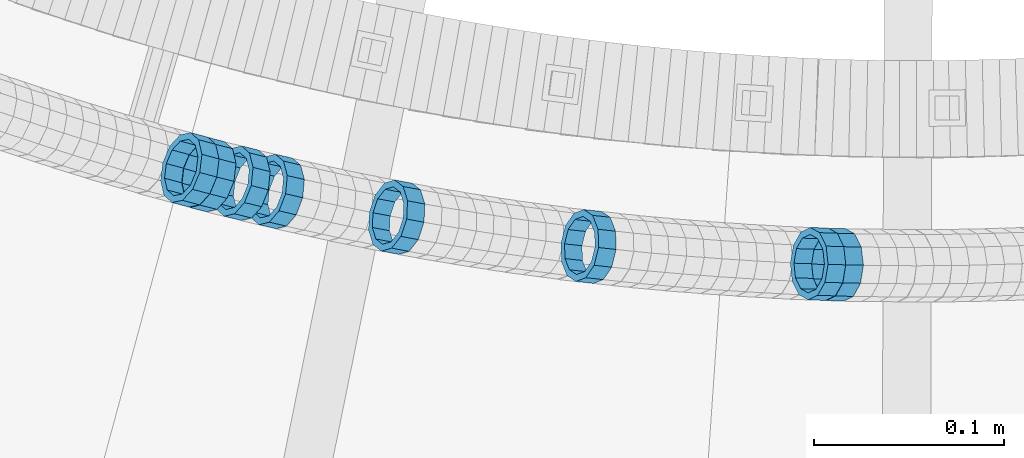
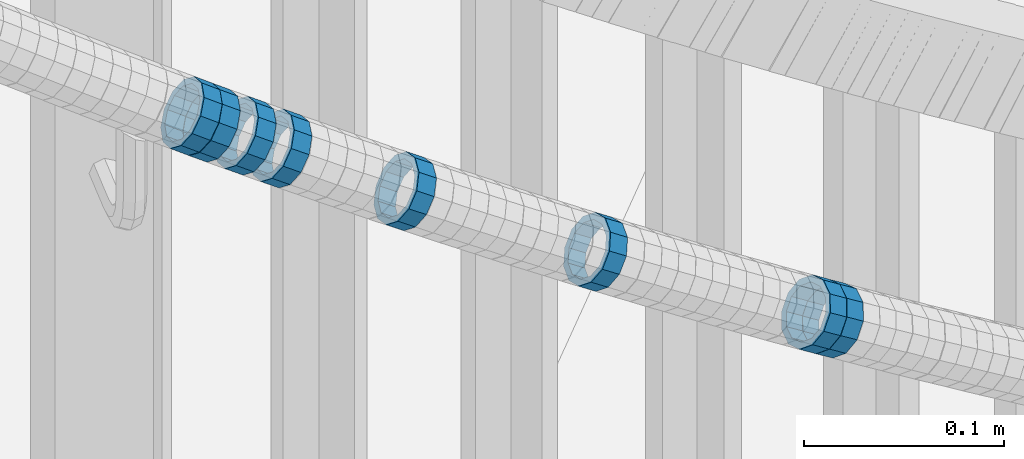
# One storey, part 686 of 975: 8 members.
"""IFC2X3 building model written with IfcOpenShell, lengths in millimetres."""

from ifc_helpers import new_model, si_unit, frame, origin_with_axes, place, context, subcontext, project, spatial, faceted_brep, material, type_object, element, save


model = new_model("IFC2X3")

# Units and contexts
model_context = context("Model", 3, precision=1e-05, world=origin_with_axes())
body_context = subcontext(model_context, "Body", "Model", "MODEL_VIEW")
ifc_project = project(units=[si_unit("LENGTHUNIT", "METRE", prefix="MILLI"), si_unit("AREAUNIT", "SQUARE_METRE"), si_unit("VOLUMEUNIT", "CUBIC_METRE"), si_unit("MASSUNIT", "GRAM", prefix="KILO"), si_unit("TIMEUNIT", "SECOND"), si_unit("PLANEANGLEUNIT", "RADIAN"), si_unit("SOLIDANGLEUNIT", "STERADIAN"), si_unit("THERMODYNAMICTEMPERATUREUNIT", "DEGREE_CELSIUS"), si_unit("LUMINOUSINTENSITYUNIT", "LUMEN")], contexts=[model_context])

# Site, building, storey
site_placement = place(None, origin_with_axes())
site = spatial("IfcSite", under=ifc_project, at=site_placement, CompositionType="ELEMENT")
building_placement = place(site_placement, origin_with_axes())
building = spatial("IfcBuilding", under=site, at=building_placement, Name="Undefined", CompositionType="ELEMENT")
storey_placement = place(building_placement, origin_with_axes())
storey = spatial("IfcBuildingStorey", under=building, at=storey_placement, Name="Undefined", CompositionType="ELEMENT", Elevation=0.0)

# Members
ifc_material = material()
member_type = type_object("IfcMemberType", PredefinedType="NOTDEFINED")
member_1_placement = place(storey_placement, frame((34566.3645562192, 1933.58696290878, 4310.87991200936), z_axis=(-0.108059180815137, -0.994144463064379, -1.17480340122711e-10), x_axis=(-0.846462505067043, 0.0920067940072997, 0.524438726041588)))
element("IfcMember", 1, at=member_1_placement, inside=storey, type_object=member_type, material=ifc_material, Name="WALL", context=body_context, shape_type="Brep", body=[
    faceted_brep([(-2.1246523829177e-07, -15.367000000002, 0.0), (-1.83998054126278e-07, -13.3082123799541, 7.68350000000009), (10.8747413762467, -13.3082123799468, 7.68349999999737), (10.8747413762612, -15.3669999999911, -4.54747350886464e-12), (-1.06232619145885e-07, -7.68349999999919, 13.3082123799559), (10.8747413762321, -7.68350000000282, 13.3082123799559), (-3.63797880709171e-12, 3.63797880709171e-12, 15.3670000000002), (10.8747413762212, -7.27595761418343e-12, 15.3670000000029), (1.06225343188271e-07, 7.68350000000646, 13.3082123799559), (10.8747413762139, 7.68349999998827, 13.3082123799586), (1.8399441614747e-07, 13.308212379965, 7.68350000000009), (10.8747413762212, 13.3082123799504, 7.683500000001), (2.12461600312963e-07, 15.3670000000093, 0.0), (10.8747413762285, 15.3669999999984, 9.09494701772928e-13), (1.8399441614747e-07, 13.308212379965, -7.68350000000009), (10.8747413762394, 13.3082123799613, -7.683500000001), (1.06225343188271e-07, 7.68350000000646, -13.3082123799559), (10.874741376254, 7.68350000001374, -13.3082123799604), (-3.63797880709171e-12, 3.63797880709171e-12, -15.3670000000002), (10.8747413762685, 1.81898940354586e-11, -15.3670000000056), (-1.06232619145885e-07, -7.68349999999919, -13.3082123799559), (10.8747413762758, -7.683499999981, -13.3082123799632), (-1.83998054126278e-07, -13.3082123799541, -7.68350000000009), (10.8747413762721, -13.3082123799359, -7.68350000000737), (-2.63386027654633e-07, -19.0500000000029, 0.0), (-2.28097633225843e-07, -16.4977839420972, -9.52499999999964), (10.8747413762867, -16.4977839420681, -9.52500000000873), (10.8747413762685, -19.0499999999847, -6.3664629124105e-12), (-1.31691194837913e-07, -9.52500000000146, -16.4977839420935), (10.8747413762831, -9.52499999997599, -16.4977839421026), (-3.63797880709171e-12, 3.63797880709171e-12, -19.0500000000002), (10.8747413762758, 2.5465851649642e-11, -19.0500000000084), (1.31687556859106e-07, 9.52500000000509, -16.4977839420935), (10.8747413762612, 9.52500000001601, -16.497783942099), (2.28097633225843e-07, 16.4977839421044, -9.52499999999964), (10.8747413762394, 16.4977839421008, -9.52500000000146), (2.63382389675826e-07, 19.0500000000138, 0.0), (10.8747413762248, 19.0499999999956, 0.0), (2.28097633225843e-07, 16.4977839421044, 9.52499999999964), (10.8747413762103, 16.497783942079, 9.52500000000418), (1.31687556859106e-07, 9.52500000000509, 16.4977839420935), (10.8747413762067, 9.52499999998327, 16.4977839420981), (-3.63797880709171e-12, 3.63797880709171e-12, 19.0500000000002), (10.8747413762212, -1.09139364212751e-11, 19.0500000000029), (-1.31691194837913e-07, -9.52500000000146, 16.4977839420935), (10.8747413762358, -9.52500000000146, 16.4977839420944), (-2.28097633225843e-07, -16.4977839420972, 9.52499999999964), (10.874741376254, -16.4977839420862, 9.524999999996)], [[[0, 1, 2, 3]], [[1, 4, 5, 2]], [[4, 6, 7, 5]], [[6, 8, 9, 7]], [[8, 10, 11, 9]], [[10, 12, 13, 11]], [[12, 14, 15, 13]], [[14, 16, 17, 15]], [[16, 18, 19, 17]], [[18, 20, 21, 19]], [[20, 22, 23, 21]], [[22, 0, 3, 23]], [[24, 25, 26, 27]], [[25, 28, 29, 26]], [[28, 30, 31, 29]], [[30, 32, 33, 31]], [[32, 34, 35, 33]], [[34, 36, 37, 35]], [[36, 38, 39, 37]], [[38, 40, 41, 39]], [[40, 42, 43, 41]], [[42, 44, 45, 43]], [[44, 46, 47, 45]], [[46, 24, 27, 47]], [[29, 31, 33, 35, 37, 39, 41, 43, 45, 47, 27, 26], [5, 7, 9, 11, 13, 15, 17, 19, 21, 23, 3, 2]], [[46, 44, 42, 40, 38, 36, 34, 32, 30, 28, 25, 24], [22, 20, 18, 16, 14, 12, 10, 8, 6, 4, 1, 0]]]),
])
member_2_placement = place(storey_placement, frame((34465.3784460587, 1948.64155464234, 4373.87835013604), z_axis=(-0.183636289961243, -0.982994258889273, -1.0938492778223e-11), x_axis=(-0.837049277629175, 0.156371842930714, 0.524305591767748)))
element("IfcMember", 2, at=member_2_placement, inside=storey, type_object=member_type, material=ifc_material, Name="WALL", context=body_context, shape_type="Brep", body=[
    faceted_brep([(-2.1246523829177e-07, -15.367000000002, 0.0), (-1.83998054126278e-07, -13.3082123799541, 7.68350000000009), (10.8747413762467, -13.3082123799468, 7.68349999999737), (10.8747413762612, -15.3669999999911, -4.54747350886464e-12), (-1.06232619145885e-07, -7.68349999999919, 13.3082123799559), (10.8747413762321, -7.68350000000282, 13.3082123799559), (-3.63797880709171e-12, 3.63797880709171e-12, 15.3670000000002), (10.8747413762212, -7.27595761418343e-12, 15.3670000000029), (1.06225343188271e-07, 7.68350000000646, 13.3082123799559), (10.8747413762139, 7.68349999998827, 13.3082123799586), (1.8399441614747e-07, 13.308212379965, 7.68350000000009), (10.8747413762212, 13.3082123799504, 7.683500000001), (2.12461600312963e-07, 15.3670000000093, 0.0), (10.8747413762285, 15.3669999999984, 9.09494701772928e-13), (1.8399441614747e-07, 13.308212379965, -7.68350000000009), (10.8747413762394, 13.3082123799613, -7.683500000001), (1.06225343188271e-07, 7.68350000000646, -13.3082123799559), (10.874741376254, 7.68350000001374, -13.3082123799604), (-3.63797880709171e-12, 3.63797880709171e-12, -15.3670000000002), (10.8747413762685, 1.81898940354586e-11, -15.3670000000056), (-1.06232619145885e-07, -7.68349999999919, -13.3082123799559), (10.8747413762758, -7.683499999981, -13.3082123799632), (-1.83998054126278e-07, -13.3082123799541, -7.68350000000009), (10.8747413762721, -13.3082123799359, -7.68350000000737), (-2.63386027654633e-07, -19.0500000000029, 0.0), (-2.28097633225843e-07, -16.4977839420972, -9.52499999999964), (10.8747413762867, -16.4977839420681, -9.52500000000873), (10.8747413762685, -19.0499999999847, -6.3664629124105e-12), (-1.31691194837913e-07, -9.52500000000146, -16.4977839420935), (10.8747413762831, -9.52499999997599, -16.4977839421026), (-3.63797880709171e-12, 3.63797880709171e-12, -19.0500000000002), (10.8747413762758, 2.5465851649642e-11, -19.0500000000084), (1.31687556859106e-07, 9.52500000000509, -16.4977839420935), (10.8747413762612, 9.52500000001601, -16.497783942099), (2.28097633225843e-07, 16.4977839421044, -9.52499999999964), (10.8747413762394, 16.4977839421008, -9.52500000000146), (2.63382389675826e-07, 19.0500000000138, 0.0), (10.8747413762248, 19.0499999999956, 0.0), (2.28097633225843e-07, 16.4977839421044, 9.52499999999964), (10.8747413762103, 16.497783942079, 9.52500000000418), (1.31687556859106e-07, 9.52500000000509, 16.4977839420935), (10.8747413762067, 9.52499999998327, 16.4977839420981), (-3.63797880709171e-12, 3.63797880709171e-12, 19.0500000000002), (10.8747413762212, -1.09139364212751e-11, 19.0500000000029), (-1.31691194837913e-07, -9.52500000000146, 16.4977839420935), (10.8747413762358, -9.52500000000146, 16.4977839420944), (-2.28097633225843e-07, -16.4977839420972, 9.52499999999964), (10.874741376254, -16.4977839420862, 9.524999999996)], [[[0, 1, 2, 3]], [[1, 4, 5, 2]], [[4, 6, 7, 5]], [[6, 8, 9, 7]], [[8, 10, 11, 9]], [[10, 12, 13, 11]], [[12, 14, 15, 13]], [[14, 16, 17, 15]], [[16, 18, 19, 17]], [[18, 20, 21, 19]], [[20, 22, 23, 21]], [[22, 0, 3, 23]], [[24, 25, 26, 27]], [[25, 28, 29, 26]], [[28, 30, 31, 29]], [[30, 32, 33, 31]], [[32, 34, 35, 33]], [[34, 36, 37, 35]], [[36, 38, 39, 37]], [[38, 40, 41, 39]], [[40, 42, 43, 41]], [[42, 44, 45, 43]], [[44, 46, 47, 45]], [[46, 24, 27, 47]], [[29, 31, 33, 35, 37, 39, 41, 43, 45, 47, 27, 26], [5, 7, 9, 11, 13, 15, 17, 19, 21, 23, 3, 2]], [[46, 44, 42, 40, 38, 36, 34, 32, 30, 28, 25, 24], [22, 20, 18, 16, 14, 12, 10, 8, 6, 4, 1, 0]]]),
])
member_3_placement = place(storey_placement, frame((34383.6000009699, 1966.27767457809, 4425.47471250728), z_axis=(-0.237453090392992, -0.97139900651731, 3.05371941067278e-10), x_axis=(-0.827361060912874, 0.202243814978718, 0.523995337944888)))
element("IfcMember", 3, at=member_3_placement, inside=storey, type_object=member_type, material=ifc_material, Name="WALL", context=body_context, shape_type="Brep", body=[
    faceted_brep([(-2.1246523829177e-07, -15.367000000002, 0.0), (-1.83998054126278e-07, -13.3082123799541, 7.68350000000009), (10.8784190028109, -13.3082123799541, 7.68349999999555), (10.8784190028309, -15.3669999999929, 2.5465851649642e-11), (-1.06232619145885e-07, -7.68349999999919, 13.3082123799559), (10.8784190027873, -7.68350000000464, 13.308212379925), (-3.63797880709171e-12, 3.63797880709171e-12, 15.3670000000002), (10.8784190027782, -9.09494701772928e-12, 15.3669999999584), (1.06225343188271e-07, 7.68350000000646, 13.3082123799559), (10.8784190027691, 7.68349999998645, 13.3082123798995), (1.8399441614747e-07, 13.308212379965, 7.68350000000009), (10.8784190027764, 13.3082123799431, 7.68349999995553), (2.12461600312963e-07, 15.3670000000093, 0.0), (10.8784190027891, 15.3669999999929, -2.91038304567337e-11), (1.8399441614747e-07, 13.308212379965, -7.68350000000009), (10.8784190028055, 13.3082123799541, -7.68350000000646), (1.06225343188271e-07, 7.68350000000646, -13.3082123799559), (10.8784190028236, 7.68350000000464, -13.3082123799431), (-3.63797880709171e-12, 3.63797880709171e-12, -15.3670000000002), (10.87841900284, 1.2732925824821e-11, -15.366999999962), (-1.06232619145885e-07, -7.68349999999919, -13.3082123799559), (10.8784190028437, -7.68349999998463, -13.308212379914), (-1.83998054126278e-07, -13.3082123799541, -7.68350000000009), (10.8784190028437, -13.3082123799413, -7.68349999996281), (-2.63386027654633e-07, -19.0500000000029, 0.0), (-2.28097633225843e-07, -16.4977839420972, -9.52499999999964), (10.8784190028491, -16.4977839420771, -9.52499999995416), (10.8784190028346, -19.0499999999902, 2.91038304567337e-11), (-1.31691194837913e-07, -9.52500000000146, -16.4977839420935), (10.8784190028582, -9.52499999998145, -16.497783942039), (-3.63797880709171e-12, 3.63797880709171e-12, -19.0500000000002), (10.8784190028473, 1.63709046319127e-11, -19.0499999999556), (1.31687556859106e-07, 9.52500000000509, -16.4977839420935), (10.8784190028291, 9.52500000000691, -16.4977839420753), (2.28097633225843e-07, 16.4977839421044, -9.52499999999964), (10.8784190028073, 16.4977839420917, -9.52500000000509), (2.63382389675826e-07, 19.0500000000138, 0.0), (10.8784190027836, 19.0499999999884, -4.00177668780088e-11), (2.28097633225843e-07, 16.4977839421044, 9.52499999999964), (10.8784190027654, 16.4977839420771, 9.52499999994325), (1.31687556859106e-07, 9.52500000000509, 16.4977839420935), (10.8784190027636, 9.52499999998327, 16.4977839420317), (-3.63797880709171e-12, 3.63797880709171e-12, 19.0500000000002), (10.8784190027709, -1.63709046319127e-11, 19.0499999999447), (-1.31691194837913e-07, -9.52500000000146, 16.4977839420935), (10.8784190027854, -9.52500000000691, 16.4977839420644), (-2.28097633225843e-07, -16.4977839420972, 9.52499999999964), (10.8784190028091, -16.4977839420899, 9.52500000000146)], [[[0, 1, 2, 3]], [[1, 4, 5, 2]], [[4, 6, 7, 5]], [[6, 8, 9, 7]], [[8, 10, 11, 9]], [[10, 12, 13, 11]], [[12, 14, 15, 13]], [[14, 16, 17, 15]], [[16, 18, 19, 17]], [[18, 20, 21, 19]], [[20, 22, 23, 21]], [[22, 0, 3, 23]], [[24, 25, 26, 27]], [[25, 28, 29, 26]], [[28, 30, 31, 29]], [[30, 32, 33, 31]], [[32, 34, 35, 33]], [[34, 36, 37, 35]], [[36, 38, 39, 37]], [[38, 40, 41, 39]], [[40, 42, 43, 41]], [[42, 44, 45, 43]], [[44, 46, 47, 45]], [[46, 24, 27, 47]], [[29, 31, 33, 35, 37, 39, 41, 43, 45, 47, 27, 26], [5, 7, 9, 11, 13, 15, 17, 19, 21, 23, 3, 2]], [[46, 44, 42, 40, 38, 36, 34, 32, 30, 28, 25, 24], [22, 20, 18, 16, 14, 12, 10, 8, 6, 4, 1, 0]]]),
])
member_4_placement = place(storey_placement, frame((34365.5436551229, 1970.77425866008, 4436.96308367795), z_axis=(-0.247598267861853, -0.968862785822538, -5.51672201254405e-11), x_axis=(-0.825792337888587, 0.211035819971522, 0.523001813929406)))
element("IfcMember", 4, at=member_4_placement, inside=storey, type_object=member_type, material=ifc_material, Name="WALL", context=body_context, shape_type="Brep", body=[
    faceted_brep([(-2.1246523829177e-07, -15.367000000002, 0.0), (-1.83998054126278e-07, -13.3082123799541, 7.68350000000009), (10.9004587059244, -13.3082123799686, 7.68350000000282), (10.9004587059426, -15.3670000000093, 9.09494701772928e-13), (-1.06232619145885e-07, -7.68349999999919, 13.3082123799559), (10.9004587059244, -7.68350000001737, 13.3082123799586), (-3.63797880709171e-12, 3.63797880709171e-12, 15.3670000000002), (10.9004587059353, -1.45519152283669e-11, 15.3670000000029), (1.06225343188271e-07, 7.68350000000646, 13.3082123799559), (10.9004587059571, 7.68349999999555, 13.308212379955), (1.8399441614747e-07, 13.308212379965, 7.68350000000009), (10.9004587059753, 13.308212379965, 7.68349999999691), (2.12461600312963e-07, 15.3670000000093, 0.0), (10.9004587059935, 15.3670000000202, -5.45696821063757e-12), (1.8399441614747e-07, 13.308212379965, -7.68350000000009), (10.9004587060081, 13.3082123799832, -7.68350000000737), (1.06225343188271e-07, 7.68350000000646, -13.3082123799559), (10.9004587060081, 7.68350000002829, -13.3082123799632), (-3.63797880709171e-12, 3.63797880709171e-12, -15.3670000000002), (10.9004587060008, 2.91038304567337e-11, -15.3670000000075), (-1.06232619145885e-07, -7.68349999999919, -13.3082123799559), (10.900458705979, -7.683499999981, -13.3082123799595), (-1.83998054126278e-07, -13.3082123799541, -7.68350000000009), (10.9004587059608, -13.3082123799504, -7.68350000000191), (-2.63386027654633e-07, -19.0500000000029, 0.0), (-2.28097633225843e-07, -16.4977839420972, -9.52499999999964), (10.9004587059499, -16.4977839420899, -9.525000000001), (10.9004587059317, -19.0500000000102, 1.81898940354586e-12), (-1.31691194837913e-07, -9.52500000000146, -16.4977839420935), (10.9004587059826, -9.52499999997963, -16.497783942099), (-3.63797880709171e-12, 3.63797880709171e-12, -19.0500000000002), (10.9004587060008, 2.91038304567337e-11, -19.0500000000084), (1.31687556859106e-07, 9.52500000000509, -16.4977839420935), (10.900458706019, 9.52500000003783, -16.4977839421026), (2.28097633225843e-07, 16.4977839421044, -9.52499999999964), (10.900458706019, 16.4977839421263, -9.52500000000873), (2.63382389675826e-07, 19.0500000000138, 0.0), (10.9004587060044, 19.0500000000247, -6.82121026329696e-12), (2.28097633225843e-07, 16.4977839421044, 9.52499999999964), (10.9004587059826, 16.4977839421044, 9.52499999999736), (1.31687556859106e-07, 9.52500000000509, 16.4977839420935), (10.9004587059571, 9.52499999999418, 16.497783942094), (-3.63797880709171e-12, 3.63797880709171e-12, 19.0500000000002), (10.900458705928, -2.18278728425503e-11, 19.0500000000038), (-1.31691194837913e-07, -9.52500000000146, 16.4977839420935), (10.9004587059135, -9.52500000002328, 16.4977839420981), (-2.28097633225843e-07, -16.4977839420972, 9.52499999999964), (10.9004587059171, -16.4977839421153, 9.52500000000373)], [[[0, 1, 2, 3]], [[1, 4, 5, 2]], [[4, 6, 7, 5]], [[6, 8, 9, 7]], [[8, 10, 11, 9]], [[10, 12, 13, 11]], [[12, 14, 15, 13]], [[14, 16, 17, 15]], [[16, 18, 19, 17]], [[18, 20, 21, 19]], [[20, 22, 23, 21]], [[22, 0, 3, 23]], [[24, 25, 26, 27]], [[25, 28, 29, 26]], [[28, 30, 31, 29]], [[30, 32, 33, 31]], [[32, 34, 35, 33]], [[34, 36, 37, 35]], [[36, 38, 39, 37]], [[38, 40, 41, 39]], [[40, 42, 43, 41]], [[42, 44, 45, 43]], [[44, 46, 47, 45]], [[46, 24, 27, 47]], [[29, 31, 33, 35, 37, 39, 41, 43, 45, 47, 27, 26], [5, 7, 9, 11, 13, 15, 17, 19, 21, 23, 3, 2]], [[46, 44, 42, 40, 38, 36, 34, 32, 30, 28, 25, 24], [22, 20, 18, 16, 14, 12, 10, 8, 6, 4, 1, 0]]]),
])
member_5_placement = place(storey_placement, frame((34356.4670702845, 1973.20193638082, 4442.72882761589), z_axis=(-0.257662650594451, -0.966234939592148, -1.78564732777886e-10), x_axis=(-0.820217943766509, 0.218724784937739, 0.528584896849485)))
element("IfcMember", 5, at=member_5_placement, inside=storey, type_object=member_type, material=ifc_material, Name="WALL", context=body_context, shape_type="Brep", body=[
    faceted_brep([(-2.1246523829177e-07, -15.367000000002, 0.0), (-1.83998054126278e-07, -13.3082123799541, 7.68350000000009), (10.9726933794955, -13.3082123799577, 7.68349999999873), (10.9726933795027, -15.3669999999984, -3.18323145620525e-12), (-1.06232619145885e-07, -7.68349999999919, 13.3082123799559), (10.9726933794846, -7.6835000000101, 13.308212379955), (-3.63797880709171e-12, 3.63797880709171e-12, 15.3670000000002), (10.9726933794773, -1.09139364212751e-11, 15.3670000000011), (1.06225343188271e-07, 7.68350000000646, 13.3082123799559), (10.9726933794773, 7.68349999998827, 13.3082123799563), (1.8399441614747e-07, 13.308212379965, 7.68350000000009), (10.9726933794846, 13.3082123799504, 7.68350000000146), (2.12461600312963e-07, 15.3670000000093, 0.0), (10.9726933794882, 15.3669999999984, 9.09494701772928e-13), (1.8399441614747e-07, 13.308212379965, -7.68350000000009), (10.9726933794955, 13.3082123799613, -7.68350000000055), (1.06225343188271e-07, 7.68350000000646, -13.3082123799559), (10.97269337951, 7.68350000001374, -13.3082123799572), (-3.63797880709171e-12, 3.63797880709171e-12, -15.3670000000002), (10.97269337951, 1.09139364212751e-11, -15.3670000000029), (-1.06232619145885e-07, -7.68349999999919, -13.3082123799559), (10.9726933795137, -7.68349999998463, -13.3082123799586), (-1.83998054126278e-07, -13.3082123799541, -7.68350000000009), (10.9726933795064, -13.3082123799468, -7.68350000000328), (-2.63386027654633e-07, -19.0500000000029, 0.0), (-2.28097633225843e-07, -16.4977839420972, -9.52499999999964), (10.97269337951, -16.4977839420826, -9.52500000000418), (10.9726933795027, -19.0499999999993, -2.27373675443232e-12), (-1.31691194837913e-07, -9.52500000000146, -16.4977839420935), (10.9726933795137, -9.52499999998327, -16.4977839420976), (-3.63797880709171e-12, 3.63797880709171e-12, -19.0500000000002), (10.9726933795209, 1.81898940354586e-11, -19.0500000000034), (1.31687556859106e-07, 9.52500000000509, -16.4977839420935), (10.97269337951, 9.52500000001237, -16.4977839420958), (2.28097633225843e-07, 16.4977839421044, -9.52499999999964), (10.9726933795027, 16.4977839421008, -9.525000000001), (2.63382389675826e-07, 19.0500000000138, 0.0), (10.9726933794882, 19.0499999999993, 4.54747350886464e-13), (2.28097633225843e-07, 16.4977839421044, 9.52499999999964), (10.9726933794809, 16.4977839420826, 9.52500000000236), (1.31687556859106e-07, 9.52500000000509, 16.4977839420935), (10.97269337947, 9.5249999999869, 16.4977839420967), (-3.63797880709171e-12, 3.63797880709171e-12, 19.0500000000002), (10.9726933794736, -1.81898940354586e-11, 19.0500000000015), (-1.31691194837913e-07, -9.52500000000146, 16.4977839420935), (10.9726933794809, -9.52500000001237, 16.4977839420931), (-2.28097633225843e-07, -16.4977839420972, 9.52499999999964), (10.9726933794882, -16.4977839420972, 9.52499999999827)], [[[0, 1, 2, 3]], [[1, 4, 5, 2]], [[4, 6, 7, 5]], [[6, 8, 9, 7]], [[8, 10, 11, 9]], [[10, 12, 13, 11]], [[12, 14, 15, 13]], [[14, 16, 17, 15]], [[16, 18, 19, 17]], [[18, 20, 21, 19]], [[20, 22, 23, 21]], [[22, 0, 3, 23]], [[24, 25, 26, 27]], [[25, 28, 29, 26]], [[28, 30, 31, 29]], [[30, 32, 33, 31]], [[32, 34, 35, 33]], [[34, 36, 37, 35]], [[36, 38, 39, 37]], [[38, 40, 41, 39]], [[40, 42, 43, 41]], [[42, 44, 45, 43]], [[44, 46, 47, 45]], [[46, 24, 27, 47]], [[29, 31, 33, 35, 37, 39, 41, 43, 45, 47, 27, 26], [5, 7, 9, 11, 13, 15, 17, 19, 21, 23, 3, 2]], [[46, 44, 42, 40, 38, 36, 34, 32, 30, 28, 25, 24], [22, 20, 18, 16, 14, 12, 10, 8, 6, 4, 1, 0]]]),
])
member_6_placement = place(storey_placement, frame((34696.4457803731, 1924.42138784444, 4230.45692096782), z_axis=(-0.0215004047140101, -0.999768839580997, -1.69680788530968e-10), x_axis=(-0.852457969985877, 0.018332428999697, 0.52247423999134)))
element("IfcMember", 6, at=member_6_placement, inside=storey, type_object=member_type, material=ifc_material, Name="WALL", context=body_context, shape_type="Brep", body=[
    faceted_brep([(-2.1246523829177e-07, -15.367000000002, 0.0), (-1.83998054126278e-07, -13.3082123799541, 7.68350000000009), (10.9055031979988, -13.3082123799322, 7.68349999999873), (10.9055031979988, -15.3669999999729, -1.81898940354586e-12), (-1.06232619145885e-07, -7.68349999999919, 13.3082123799559), (10.9055031979842, -7.683499999981, 13.3082123799552), (-3.63797880709171e-12, 3.63797880709171e-12, 15.3670000000002), (10.9055031979697, 7.27595761418343e-12, 15.3670000000002), (1.06225343188271e-07, 7.68350000000646, 13.3082123799559), (10.9055031979478, 7.68349999999191, 13.3082123799561), (1.8399441614747e-07, 13.308212379965, 7.68350000000009), (10.9055031979333, 13.3082123799395, 7.68350000000078), (2.12461600312963e-07, 15.3670000000093, 0.0), (10.9055031979187, 15.3669999999802, 4.54747350886464e-13), (1.8399441614747e-07, 13.308212379965, -7.68350000000009), (10.9055031979187, 13.3082123799395, -7.68350000000009), (1.06225343188271e-07, 7.68350000000646, -13.3082123799559), (10.9055031979296, 7.68349999999191, -13.3082123799561), (-3.63797880709171e-12, 3.63797880709171e-12, -15.3670000000002), (10.9055031979478, 3.63797880709171e-12, -15.3670000000013), (-1.06232619145885e-07, -7.68349999999919, -13.3082123799559), (10.9055031979697, -7.683499999981, -13.3082123799575), (-1.83998054126278e-07, -13.3082123799541, -7.68350000000009), (10.9055031979842, -13.3082123799286, -7.68350000000214), (-2.63386027654633e-07, -19.0500000000029, 0.0), (-2.28097633225843e-07, -16.4977839420972, -9.52499999999964), (10.9055031979879, -16.4977839420681, -9.52500000000214), (10.9055031980097, -19.0499999999629, -2.04636307898909e-12), (-1.31691194837913e-07, -9.52500000000146, -16.4977839420935), (10.9055031979624, -9.52499999998327, -16.4977839420956), (-3.63797880709171e-12, 3.63797880709171e-12, -19.0500000000002), (10.9055031979406, 3.63797880709171e-12, -19.0500000000015), (1.31687556859106e-07, 9.52500000000509, -16.4977839420935), (10.9055031979151, 9.5249999999869, -16.4977839420942), (2.28097633225843e-07, 16.4977839421044, -9.52499999999964), (10.9055031979115, 16.4977839420717, -9.52499999999986), (2.63382389675826e-07, 19.0500000000138, 0.0), (10.9055031979115, 19.0499999999774, 6.82121026329696e-13), (2.28097633225843e-07, 16.4977839421044, 9.52499999999964), (10.9055031979296, 16.4977839420753, 9.52500000000123), (1.31687556859106e-07, 9.52500000000509, 16.4977839420935), (10.9055031979515, 9.52499999999054, 16.4977839420942), (-3.63797880709171e-12, 3.63797880709171e-12, 19.0500000000002), (10.9055031979733, 7.27595761418343e-12, 19.0500000000004), (-1.31691194837913e-07, -9.52500000000146, 16.4977839420935), (10.9055031979988, -9.52499999997599, 16.4977839420933), (-2.28097633225843e-07, -16.4977839420972, 9.52499999999964), (10.905503198006, -16.4977839420644, 9.52499999999873)], [[[0, 1, 2, 3]], [[1, 4, 5, 2]], [[4, 6, 7, 5]], [[6, 8, 9, 7]], [[8, 10, 11, 9]], [[10, 12, 13, 11]], [[12, 14, 15, 13]], [[14, 16, 17, 15]], [[16, 18, 19, 17]], [[18, 20, 21, 19]], [[20, 22, 23, 21]], [[22, 0, 3, 23]], [[24, 25, 26, 27]], [[25, 28, 29, 26]], [[28, 30, 31, 29]], [[30, 32, 33, 31]], [[32, 34, 35, 33]], [[34, 36, 37, 35]], [[36, 38, 39, 37]], [[38, 40, 41, 39]], [[40, 42, 43, 41]], [[42, 44, 45, 43]], [[44, 46, 47, 45]], [[46, 24, 27, 47]], [[29, 31, 33, 35, 37, 39, 41, 43, 45, 47, 27, 26], [5, 7, 9, 11, 13, 15, 17, 19, 21, 23, 3, 2]], [[46, 44, 42, 40, 38, 36, 34, 32, 30, 28, 25, 24], [22, 20, 18, 16, 14, 12, 10, 8, 6, 4, 1, 0]]]),
])
member_7_placement = place(storey_placement, frame((34687.1507429922, 1924.72822596958, 4236.15564049049), z_axis=(-0.0322412936828041, -0.999480114350285, -2.04656316782348e-10), x_axis=(-0.852278968975342, 0.0274928699992032, 0.522364528984821)))
element("IfcMember", 7, at=member_7_placement, inside=storey, type_object=member_type, material=ifc_material, Name="WALL", context=body_context, shape_type="Brep", body=[
    faceted_brep([(-2.1246523829177e-07, -15.367000000002, 0.0), (-1.83998054126278e-07, -13.3082123799541, 7.68350000000009), (10.9055031979988, -13.3082123799322, 7.68349999999873), (10.9055031979988, -15.3669999999729, -1.81898940354586e-12), (-1.06232619145885e-07, -7.68349999999919, 13.3082123799559), (10.9055031979842, -7.683499999981, 13.3082123799552), (-3.63797880709171e-12, 3.63797880709171e-12, 15.3670000000002), (10.9055031979697, 7.27595761418343e-12, 15.3670000000002), (1.06225343188271e-07, 7.68350000000646, 13.3082123799559), (10.9055031979478, 7.68349999999191, 13.3082123799561), (1.8399441614747e-07, 13.308212379965, 7.68350000000009), (10.9055031979333, 13.3082123799395, 7.68350000000078), (2.12461600312963e-07, 15.3670000000093, 0.0), (10.9055031979187, 15.3669999999802, 4.54747350886464e-13), (1.8399441614747e-07, 13.308212379965, -7.68350000000009), (10.9055031979187, 13.3082123799395, -7.68350000000009), (1.06225343188271e-07, 7.68350000000646, -13.3082123799559), (10.9055031979296, 7.68349999999191, -13.3082123799561), (-3.63797880709171e-12, 3.63797880709171e-12, -15.3670000000002), (10.9055031979478, 3.63797880709171e-12, -15.3670000000013), (-1.06232619145885e-07, -7.68349999999919, -13.3082123799559), (10.9055031979697, -7.683499999981, -13.3082123799575), (-1.83998054126278e-07, -13.3082123799541, -7.68350000000009), (10.9055031979842, -13.3082123799286, -7.68350000000214), (-2.63386027654633e-07, -19.0500000000029, 0.0), (-2.28097633225843e-07, -16.4977839420972, -9.52499999999964), (10.9055031979879, -16.4977839420681, -9.52500000000214), (10.9055031980097, -19.0499999999629, -2.04636307898909e-12), (-1.31691194837913e-07, -9.52500000000146, -16.4977839420935), (10.9055031979624, -9.52499999998327, -16.4977839420956), (-3.63797880709171e-12, 3.63797880709171e-12, -19.0500000000002), (10.9055031979406, 3.63797880709171e-12, -19.0500000000015), (1.31687556859106e-07, 9.52500000000509, -16.4977839420935), (10.9055031979151, 9.5249999999869, -16.4977839420942), (2.28097633225843e-07, 16.4977839421044, -9.52499999999964), (10.9055031979115, 16.4977839420717, -9.52499999999986), (2.63382389675826e-07, 19.0500000000138, 0.0), (10.9055031979115, 19.0499999999774, 6.82121026329696e-13), (2.28097633225843e-07, 16.4977839421044, 9.52499999999964), (10.9055031979296, 16.4977839420753, 9.52500000000123), (1.31687556859106e-07, 9.52500000000509, 16.4977839420935), (10.9055031979515, 9.52499999999054, 16.4977839420942), (-3.63797880709171e-12, 3.63797880709171e-12, 19.0500000000002), (10.9055031979733, 7.27595761418343e-12, 19.0500000000004), (-1.31691194837913e-07, -9.52500000000146, 16.4977839420935), (10.9055031979988, -9.52499999997599, 16.4977839420933), (-2.28097633225843e-07, -16.4977839420972, 9.52499999999964), (10.905503198006, -16.4977839420644, 9.52499999999873)], [[[0, 1, 2, 3]], [[1, 4, 5, 2]], [[4, 6, 7, 5]], [[6, 8, 9, 7]], [[8, 10, 11, 9]], [[10, 12, 13, 11]], [[12, 14, 15, 13]], [[14, 16, 17, 15]], [[16, 18, 19, 17]], [[18, 20, 21, 19]], [[20, 22, 23, 21]], [[22, 0, 3, 23]], [[24, 25, 26, 27]], [[25, 28, 29, 26]], [[28, 30, 31, 29]], [[30, 32, 33, 31]], [[32, 34, 35, 33]], [[34, 36, 37, 35]], [[36, 38, 39, 37]], [[38, 40, 41, 39]], [[40, 42, 43, 41]], [[42, 44, 45, 43]], [[44, 46, 47, 45]], [[46, 24, 27, 47]], [[29, 31, 33, 35, 37, 39, 41, 43, 45, 47, 27, 26], [5, 7, 9, 11, 13, 15, 17, 19, 21, 23, 3, 2]], [[46, 44, 42, 40, 38, 36, 34, 32, 30, 28, 25, 24], [22, 20, 18, 16, 14, 12, 10, 8, 6, 4, 1, 0]]]),
])
member_8_placement = place(storey_placement, frame((34401.657911761, 1961.97975525019, 4413.9859153184), z_axis=(-0.227229615370656, -0.973841209796805, -3.49525180354249e-10), x_axis=(-0.828868445970396, 0.193402636993091, 0.524950015981273)))
element("IfcMember", 8, at=member_8_placement, inside=storey, type_object=member_type, material=ifc_material, Name="WALL", context=body_context, shape_type="Brep", body=[
    faceted_brep([(-2.1246523829177e-07, -15.367000000002, 0.0), (-1.83998054126278e-07, -13.3082123799541, 7.68350000000009), (10.8613995415399, -13.3082123799322, 7.68349999999191), (10.8613995415435, -15.3669999999729, -8.18545231595635e-12), (-1.06232619145885e-07, -7.68349999999919, 13.3082123799559), (10.8613995415217, -7.683499999981, 13.3082123799504), (-3.63797880709171e-12, 3.63797880709171e-12, 15.3670000000002), (10.8613995415071, 3.63797880709171e-12, 15.3669999999984), (1.06225343188271e-07, 7.68350000000646, 13.3082123799559), (10.861399541478, 7.68349999998463, 13.3082123799586), (1.8399441614747e-07, 13.308212379965, 7.68350000000009), (10.8613995414671, 13.3082123799322, 7.68350000000555), (2.12461600312963e-07, 15.3670000000093, 0.0), (10.8613995414562, 15.3669999999693, 7.27595761418343e-12), (1.8399441614747e-07, 13.308212379965, -7.68350000000009), (10.8613995414671, 13.3082123799322, -7.68349999999191), (1.06225343188271e-07, 7.68350000000646, -13.3082123799559), (10.861399541478, 7.683499999981, -13.3082123799513), (-3.63797880709171e-12, 3.63797880709171e-12, -15.3670000000002), (10.8613995415035, -3.63797880709171e-12, -15.3670000000002), (-1.06232619145885e-07, -7.68349999999919, -13.3082123799559), (10.8613995415253, -7.68349999998827, -13.3082123799586), (-1.83998054126278e-07, -13.3082123799541, -7.68350000000009), (10.8613995415435, -13.3082123799286, -7.68350000000828), (-2.63386027654633e-07, -19.0500000000029, 0.0), (-2.28097633225843e-07, -16.4977839420972, -9.52499999999964), (10.8613995415471, -16.4977839420717, -9.52500000000782), (10.8613995415581, -19.0499999999629, -1.09139364212751e-11), (-1.31691194837913e-07, -9.52500000000146, -16.4977839420935), (10.861399541529, -9.5249999999869, -16.4977839420972), (-3.63797880709171e-12, 3.63797880709171e-12, -19.0500000000002), (10.8613995415035, -7.27595761418343e-12, -19.0499999999984), (1.31687556859106e-07, 9.52500000000509, -16.4977839420935), (10.861399541478, 9.52499999997963, -16.497783942089), (2.28097633225843e-07, 16.4977839421044, -9.52499999999964), (10.8613995414526, 16.4977839420644, -9.52499999999236), (2.63382389675826e-07, 19.0500000000138, 0.0), (10.8613995414489, 19.0499999999665, 8.18545231595635e-12), (2.28097633225843e-07, 16.4977839421044, 9.52499999999964), (10.8613995414598, 16.4977839420644, 9.52500000000691), (1.31687556859106e-07, 9.52500000000509, 16.4977839420935), (10.8613995414744, 9.5249999999869, 16.4977839420972), (-3.63797880709171e-12, 3.63797880709171e-12, 19.0500000000002), (10.8613995414998, 3.63797880709171e-12, 19.0499999999993), (-1.31691194837913e-07, -9.52500000000146, 16.4977839420935), (10.861399541529, -9.52499999997599, 16.4977839420862), (-2.28097633225843e-07, -16.4977839420972, 9.52499999999964), (10.8613995415508, -16.4977839420644, 9.52499999999145)], [[[0, 1, 2, 3]], [[1, 4, 5, 2]], [[4, 6, 7, 5]], [[6, 8, 9, 7]], [[8, 10, 11, 9]], [[10, 12, 13, 11]], [[12, 14, 15, 13]], [[14, 16, 17, 15]], [[16, 18, 19, 17]], [[18, 20, 21, 19]], [[20, 22, 23, 21]], [[22, 0, 3, 23]], [[24, 25, 26, 27]], [[25, 28, 29, 26]], [[28, 30, 31, 29]], [[30, 32, 33, 31]], [[32, 34, 35, 33]], [[34, 36, 37, 35]], [[36, 38, 39, 37]], [[38, 40, 41, 39]], [[40, 42, 43, 41]], [[42, 44, 45, 43]], [[44, 46, 47, 45]], [[46, 24, 27, 47]], [[29, 31, 33, 35, 37, 39, 41, 43, 45, 47, 27, 26], [5, 7, 9, 11, 13, 15, 17, 19, 21, 23, 3, 2]], [[46, 44, 42, 40, 38, 36, 34, 32, 30, 28, 25, 24], [22, 20, 18, 16, 14, 12, 10, 8, 6, 4, 1, 0]]]),
])

save(model, "model.ifc")
